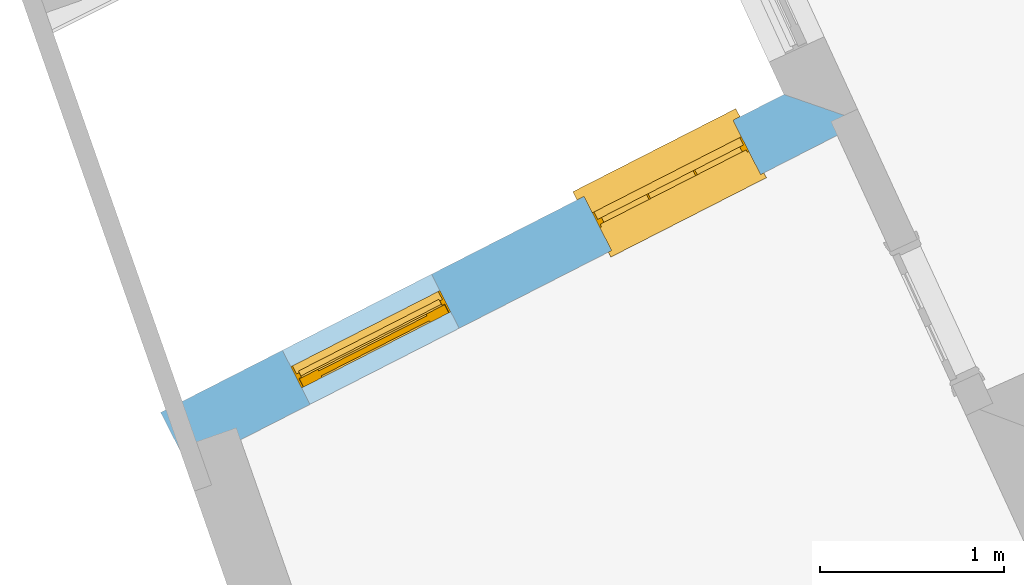
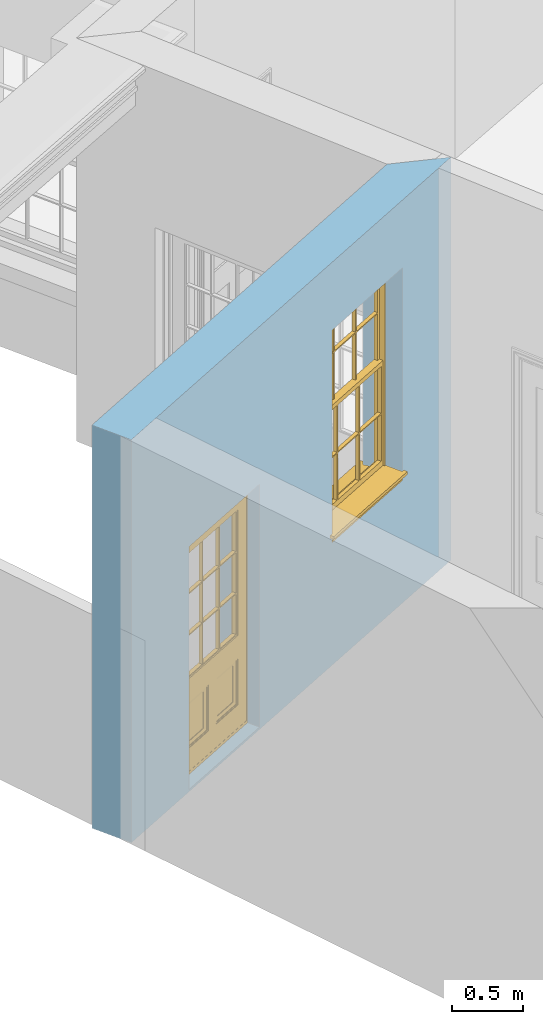
# One storey, part 2 of 10: 1 door, 1 window, 2 openings, plus 1 element that does not belong to this part.
"""IFC2X3 building model written with IfcOpenShell, lengths in metres."""

from ifc_helpers import new_model, si_unit, frame, origin, place, context, subcontext, project, spatial, polyline, outline, extrude, faceted_brep, material, layer, layer_set, layer_usage, element, fill, save


model = new_model("IFC2X3")

# Units and contexts
model_context = context("Model", 3, world=origin())
body_context = subcontext(model_context, "Body", "Model", "MODEL_VIEW")
ifc_project = project(units=[si_unit("PLANEANGLEUNIT", "RADIAN"), si_unit("MASSUNIT", "GRAM", prefix="KILO"), si_unit("FORCEUNIT", "NEWTON", prefix="KILO"), si_unit("LENGTHUNIT", "METRE")], contexts=[model_context])

# Site, building, storey
site_placement = place(None, origin())
site = spatial("IfcSite", under=ifc_project, at=site_placement, CompositionType="ELEMENT")
building_placement = place(None, origin())
building = spatial("IfcBuilding", under=site, at=building_placement, Name="Building plot-8", CompositionType="ELEMENT")
storey_placement = place(None, origin())
storey = spatial("IfcBuildingStorey", under=building, at=storey_placement, Name="Floor 0", CompositionType="ELEMENT", Elevation=0.0)

# Wall, openings, window, door
ifc_material = material(Name="Masonry")
ifc_layer = layer(ifc_material, 0.33, ventilated=False)
ifc_layer_set = layer_set([ifc_layer], Name="My Wall")
ifc_layer_usage = layer_usage(ifc_layer_set, "AXIS2", "NEGATIVE", 0.08)
wall_placement = place(storey_placement, origin())
wall = element("IfcWallStandardCase", 1, at=wall_placement, inside=storey, material=ifc_layer_usage, Name="exterior", context=body_context, shape_type="SweptSolid", body=[
    extrude(outline(polyline([(25.0188753029837, 10.5910611684611), (24.5866593596622, 10.7410148794705), (21.1992955616312, 9.01280004901607), (21.3492685706448, 8.71884750766391), (25.0188753029837, 10.5910611684611)])), origin(), (0.0, 0.0, 1.0), 3.45),
])
opening_1_placement = place(storey_placement, frame((0.0, 0.0, 1.05)))
opening_1 = element("IfcOpeningElement", 2, at=opening_1_placement, cuts=wall, Name="Opening", ObjectType="Opening", context=body_context, shape_type="SweptSolid", body=[
    extrude(outline(polyline([(24.3105588621873, 10.6001498874347), (23.4999624602768, 10.186587953488), (23.6499354692904, 9.89263541213587), (24.4605318712009, 10.3061973460826), (24.3105588621873, 10.6001498874347)])), origin(), (0.0, 0.0, 1.0), 1.82),
])
opening_2_placement = place(storey_placement, frame((0.0, 0.0, 0.02)))
opening_2 = element("IfcOpeningElement", 3, at=opening_2_placement, cuts=wall, Name="Opening", ObjectType="Opening", context=body_context, shape_type="SweptSolid", body=[
    extrude(outline(polyline([(22.6719083026935, 9.76411916628935), (21.861311900783, 9.35055723234263), (22.0112849097966, 9.05660469099047), (22.8218813117071, 9.47016662493719), (22.6719083026935, 9.76411916628935)])), origin(), (0.0, 0.0, 1.0), 2.08),
])
window_placement = place(storey_placement, frame((24.4241747781067, 10.3774585682286, 1.05), z_axis=(0.0, 0.0, 1.0), x_axis=(-0.810596401910505, -0.413561933946712, 0.0)))
window = element("IfcWindow", 4, at=window_placement, inside=storey, Name="kitchen outside window", OverallHeight=1.82, OverallWidth=0.91, context=body_context, shape_type="Brep", held_by="IfcProductRepresentation", body=[
    faceted_brep([(0.033125, -0.105, 0.975209), (0.01, -0.105, 0.975209), (0.033125, -0.105, 1.376042), (0.876875, -0.105, 0.975209), (0.876875, -0.105, 1.376042), (0.9, -0.105, 0.975209), (0.876875, -0.105, 1.386042), (0.876875, -0.105, 1.786875), (0.9, -0.105, 1.81), (0.033125, -0.105, 1.786875), (0.033125, -0.105, 1.386042), (0.01, -0.105, 1.81), (0.876875, -0.135, 1.376042), (0.876875, -0.135, 0.975209), (0.9, -0.135, 0.937083), (0.033125, -0.135, 1.786875), (0.01, -0.135, 1.81), (0.033125, -0.135, 1.386042), (0.01, -0.135, 0.937083), (0.033125, -0.135, 0.975209), (0.033125, -0.135, 1.376042), (0.876875, -0.135, 1.786875), (0.876875, -0.135, 1.386042), (0.9, -0.135, 1.81), (0.033125, -0.105, 0.937083), (0.01, -0.105, 0.937083), (0.033125, -0.105, 0.53625), (0.876875, -0.105, 0.937083), (0.876875, -0.105, 0.53625), (0.9, -0.105, 0.937083), (0.876875, -0.105, 0.52625), (0.876875, -0.105, 0.125417), (0.9, -0.105, 0.077167), (0.033125, -0.105, 0.125417), (0.033125, -0.105, 0.52625), (0.01, -0.105, 0.077167), (-0.0425, -0.25, 0.01), (-0.0425, -0.3, 0.001667), (0.0, -0.25, 0.01), (0.9525, -0.25, 0.01), (0.91, -0.25, 0.01), (0.9525, -0.3, 0.001667), (-0.02, 0.08, 0.077167), (0.0, 0.08, 0.077167), (-0.02, 0.11, 0.077167), (0.0, -0.06, 0.077167), (0.01, -0.06, 0.077167), (0.91, -0.06, 0.077167), (0.91, 0.08, 0.077167), (0.9, -0.06, 0.077167), (0.93, 0.08, 0.077167), (0.93, 0.11, 0.077167), (0.01, -0.075, 0.975209), (0.9, -0.075, 0.975209), (0.876875, -0.075, 0.125417), (0.876875, -0.075, 0.52625), (0.9, -0.075, 0.077167), (0.876875, -0.075, 0.53625), (0.876875, -0.075, 0.937083), (0.033125, -0.075, 0.125417), (0.01, -0.075, 0.077167), (0.033125, -0.075, 0.52625), (0.033125, -0.075, 0.937083), (0.033125, -0.075, 0.53625), (-0.02, 0.08, 0.052167), (-0.02, 0.11, 0.052167), (0.93, 0.11, 0.052167), (0.93, 0.08, 0.052167), (0.91, 0.08, 0.052167), (0.0, 0.08, 0.052167), (0.91, -0.15, 0.026667), (0.0, -0.15, 0.026667), (-0.0425, -0.3, -0.123333), (0.9525, -0.3, -0.123333), (-0.0425, -0.25, -0.123333), (0.9525, -0.25, -0.123333), (0.01, -0.06, 1.81), (0.9, -0.06, 1.81), (0.0, -0.06, 1.82), (0.91, -0.06, 1.82), (0.01, -0.15, 0.077167), (0.9, -0.15, 0.077167), (0.592292, -0.105, 0.125417), (0.592292, -0.075, 0.125417), (0.317708, -0.075, 0.125417), (0.317708, -0.105, 0.125417), (0.592292, -0.105, 0.53625), (0.317708, -0.105, 0.53625), (0.317708, -0.105, 0.52625), (0.592292, -0.105, 0.52625), (0.592292, -0.075, 0.53625), (0.317708, -0.075, 0.53625), (0.592292, -0.135, 1.386042), (0.592292, -0.105, 1.386042), (0.317708, -0.105, 1.386042), (0.317708, -0.135, 1.386042), (0.317708, -0.135, 1.376042), (0.592292, -0.135, 1.376042), (0.317708, -0.105, 1.376042), (0.592292, -0.105, 1.376042), (0.602292, -0.135, 1.376042), (0.592292, -0.135, 0.975209), (0.602292, -0.135, 0.975209), (0.602292, -0.105, 0.975209), (0.592292, -0.105, 0.975209), (0.602292, -0.105, 1.376042), (0.602292, -0.075, 0.53625), (0.602292, -0.105, 0.53625), (0.317708, -0.075, 0.52625), (0.307708, -0.075, 0.125417), (0.307708, -0.075, 0.52625), (0.602292, -0.075, 0.52625), (0.602292, -0.075, 0.125417), (0.592292, -0.075, 0.52625), (0.307708, -0.075, 0.53625), (0.317708, -0.075, 0.937083), (0.307708, -0.075, 0.937083), (0.602292, -0.075, 0.937083), (0.592292, -0.075, 0.937083), (0.307708, -0.105, 0.52625), (0.307708, -0.105, 0.125417), (0.307708, -0.105, 0.53625), (0.307708, -0.105, 0.937083), (0.592292, -0.105, 0.937083), (0.317708, -0.105, 0.937083), (0.602292, -0.105, 0.937083), (0.602292, -0.105, 0.52625), (0.602292, -0.105, 0.125417), (0.307708, -0.135, 1.386042), (0.307708, -0.135, 1.376042), (0.307708, -0.135, 0.975209), (0.317708, -0.135, 0.975209), (0.317708, -0.135, 1.786875), (0.307708, -0.135, 1.786875), (0.602292, -0.135, 1.786875), (0.592292, -0.135, 1.786875), (0.602292, -0.135, 1.386042), (0.602292, -0.105, 1.386042), (0.307708, -0.105, 1.386042), (0.307708, -0.105, 1.786875), (0.317708, -0.105, 1.786875), (0.592292, -0.105, 1.786875), (0.602292, -0.105, 1.786875), (0.307708, -0.105, 1.376042), (0.317708, -0.105, 0.975209), (0.307708, -0.105, 0.975209), (0.91, -0.15, 1.82), (0.9, -0.15, 1.81), (0.01, -0.15, 1.81), (0.0, -0.15, 1.82), (0.91, -0.25, 0.0), (0.0, -0.25, 0.0), (0.91, 0.08, 0.0), (0.0, 0.08, 0.0)], [[[0, 1, 2]], [[3, 4, 5]], [[6, 7, 8]], [[9, 10, 11]], [[12, 13, 14]], [[15, 16, 17]], [[18, 19, 20]], [[21, 22, 23]], [[24, 25, 26]], [[27, 28, 29]], [[30, 31, 32]], [[33, 34, 35]], [[14, 27, 29]], [[25, 24, 18]], [[36, 37, 38]], [[39, 40, 41]], [[42, 43, 44]], [[45, 46, 43]], [[47, 48, 49]], [[50, 51, 48]], [[1, 0, 52]], [[5, 53, 3]], [[54, 55, 56]], [[57, 58, 53]], [[59, 60, 61]], [[62, 63, 52]], [[48, 43, 46, 49]], [[51, 44, 43, 48]], [[64, 42, 44, 65]], [[65, 44, 51, 66]], [[66, 51, 50, 67]], [[65, 66, 68, 69]], [[60, 56, 49, 46]], [[70, 71, 38, 40]], [[37, 41, 40, 38]], [[37, 72, 73, 41]], [[74, 75, 73, 72]], [[8, 11, 76, 77]], [[76, 78, 79, 77]], [[32, 35, 80, 81]], [[81, 80, 71, 70]], [[82, 83, 84, 85]], [[86, 87, 88, 89]], [[86, 90, 91, 87]], [[92, 93, 94, 95]], [[92, 95, 96, 97]], [[96, 98, 99, 97]], [[100, 97, 101, 102]], [[103, 104, 99, 105]], [[97, 99, 104, 101]], [[102, 103, 105, 100]], [[28, 57, 106, 107]], [[108, 84, 109, 110]], [[111, 112, 83, 113]], [[114, 110, 61, 63]], [[90, 113, 108, 91]], [[115, 91, 114, 116]], [[117, 106, 90, 118]], [[111, 106, 57, 55]], [[119, 110, 109, 120]], [[34, 61, 110, 119]], [[89, 113, 83, 82]], [[88, 108, 113, 89]], [[85, 84, 108, 88]], [[121, 114, 63, 26]], [[122, 116, 114, 121]], [[123, 118, 90, 86]], [[87, 91, 115, 124]], [[107, 106, 117, 125]], [[126, 111, 55, 30]], [[127, 112, 111, 126]], [[126, 30, 28, 107]], [[88, 119, 120, 85]], [[126, 89, 82, 127]], [[125, 123, 86, 107]], [[121, 26, 34, 119]], [[124, 122, 121, 87]], [[128, 17, 20, 129]], [[96, 129, 130, 131]], [[132, 133, 128, 95]], [[134, 135, 92, 136]], [[100, 12, 22, 136]], [[137, 6, 4, 105]], [[94, 138, 139, 140]], [[137, 93, 141, 142]], [[99, 98, 94, 93]], [[143, 2, 10, 138]], [[144, 145, 143, 98]], [[129, 143, 145, 130]], [[20, 2, 143, 129]], [[131, 144, 98, 96]], [[128, 138, 10, 17]], [[133, 139, 138, 128]], [[135, 141, 93, 92]], [[95, 94, 140, 132]], [[22, 6, 137, 136]], [[136, 137, 142, 134]], [[100, 105, 4, 12]], [[107, 86, 89, 126]], [[106, 111, 113, 90]], [[91, 108, 110, 114]], [[87, 121, 119, 88]], [[97, 100, 136, 92]], [[129, 96, 95, 128]], [[98, 143, 138, 94]], [[105, 99, 93, 137]], [[131, 101, 104, 144]], [[124, 115, 118, 123]], [[132, 140, 141, 135]], [[120, 109, 59, 33]], [[15, 9, 139, 133]], [[134, 142, 7, 21]], [[31, 54, 112, 127]], [[36, 74, 72, 37]], [[39, 41, 73, 75]], [[18, 14, 101, 131]], [[23, 16, 132, 135]], [[83, 56, 60, 84]], [[52, 53, 118, 115]], [[53, 52, 144, 104]], [[11, 8, 141, 140]], [[14, 18, 124, 123]], [[2, 1, 11, 10]], [[8, 5, 4, 6]], [[57, 53, 56, 55]], [[60, 52, 63, 61]], [[26, 25, 35, 34]], [[32, 29, 28, 30]], [[14, 23, 22, 12]], [[18, 20, 17, 16]], [[19, 0, 2, 20]], [[17, 10, 9, 15]], [[12, 4, 3, 13]], [[21, 7, 6, 22]], [[27, 58, 57, 28]], [[30, 55, 54, 31]], [[33, 59, 61, 34]], [[26, 63, 62, 24]], [[5, 8, 77, 53]], [[76, 11, 1, 52]], [[46, 45, 78, 76]], [[49, 77, 79, 47]], [[70, 146, 147, 81]], [[71, 80, 148, 149]], [[19, 130, 145, 0]], [[102, 13, 3, 103]], [[116, 122, 24, 62]], [[29, 32, 81, 14]], [[80, 35, 25, 18]], [[60, 46, 76, 52]], [[77, 49, 56, 53]], [[23, 14, 81, 147]], [[16, 148, 80, 18]], [[35, 85, 120]], [[120, 33, 35]], [[127, 82, 32]], [[32, 31, 127]], [[32, 82, 85, 35]], [[102, 101, 14]], [[14, 13, 102]], [[18, 131, 130]], [[130, 19, 18]], [[134, 21, 23]], [[23, 135, 134]], [[16, 15, 133]], [[133, 132, 16]], [[11, 140, 139]], [[139, 9, 11]], [[142, 141, 8]], [[8, 7, 142]], [[23, 147, 148, 16]], [[146, 149, 148, 147]], [[52, 115, 116]], [[116, 62, 52]], [[118, 53, 117]], [[58, 117, 53]], [[27, 125, 117, 58]], [[56, 83, 112]], [[112, 54, 56]], [[109, 84, 60]], [[60, 59, 109]], [[125, 27, 14]], [[14, 123, 125]], [[122, 124, 18]], [[18, 24, 122]], [[145, 144, 52]], [[52, 0, 145]], [[103, 3, 53]], [[53, 104, 103]], [[79, 78, 149, 146]], [[78, 45, 71, 149]], [[146, 70, 47, 79]], [[150, 75, 74, 151]], [[68, 66, 67]], [[48, 68, 67, 50]], [[69, 64, 65]], [[42, 64, 69, 43]], [[69, 68, 152, 153]], [[70, 68, 48, 47]], [[150, 152, 68, 70]], [[43, 69, 71, 45]], [[69, 153, 151, 71]], [[152, 150, 151, 153]], [[38, 151, 74, 36]], [[71, 151, 38]], [[39, 75, 150, 40]], [[40, 150, 70]]]),
])
fill(opening_1, window)
door_placement = place(storey_placement, frame((22.7855242186129, 9.54142784708316, 0.02), z_axis=(0.0, 0.0, 1.0), x_axis=(-0.810596401910505, -0.413561933946712, 0.0)))
door = element("IfcDoor", 5, at=door_placement, inside=storey, Name="kitchen outside door", OverallHeight=2.08, OverallWidth=0.91, context=body_context, shape_type="Brep", held_by="IfcProductRepresentation", body=[
    faceted_brep([(0.545, -0.055, 0.265), (0.745, -0.055, 0.265), (0.745, -0.05, 0.265), (0.545, -0.05, 0.265), (0.745, -0.05, 0.58), (0.545, -0.05, 0.58), (0.545, -0.055, 0.58), (0.515, -0.06, 0.235), (0.775, -0.06, 0.235), (0.745, -0.055, 0.58), (0.515, -0.06, 0.61), (0.515, -0.065, 0.235), (0.775, -0.065, 0.235), (0.775, -0.06, 0.61), (0.515, -0.065, 0.61), (0.785, -0.065, 0.225), (0.505, -0.065, 0.225), (0.775, -0.065, 0.61), (0.505, -0.065, 0.62), (0.785, -0.065, 0.62), (0.505, -0.07, 0.225), (0.785, -0.07, 0.225), (0.505, -0.07, 0.62), (0.785, -0.07, 0.62), (0.883, -0.07, 0.075), (0.898, -0.07, 0.075), (0.405, -0.07, 0.62), (0.405, -0.07, 0.225), (0.027, -0.07, 0.075), (0.785, -0.07, 0.82), (0.125, -0.07, 0.82), (0.405, -0.065, 0.62), (0.405, -0.065, 0.225), (0.898, -0.07, 2.068), (0.027, -0.08, 0.075), (0.883, -0.08, 0.075), (0.125, -0.07, 0.225), (0.012, -0.07, 0.075), (0.785, -0.06, 0.82), (0.125, -0.06, 0.82), (0.125, -0.07, 0.62), (0.125, -0.065, 0.62), (0.395, -0.065, 0.61), (0.395, -0.065, 0.235), (0.125, -0.065, 0.225), (0.785, -0.07, 1.895), (0.027, -0.11, 0.045), (0.883, -0.11, 0.045), (0.558333, -0.06, 0.83), (0.351667, -0.06, 0.83), (0.125, -0.07, 1.895), (0.125, -0.06, 1.895), (0.785, -0.06, 1.895), (0.012, -0.07, 2.068), (0.135, -0.065, 0.61), (0.395, -0.06, 0.61), (0.395, -0.06, 0.235), (0.135, -0.065, 0.235), (0.027, -0.11, 0.027), (0.883, -0.11, 0.027), (0.568333, -0.06, 0.83), (0.558333, -0.03, 0.83), (0.351667, -0.03, 0.83), (0.341667, -0.06, 0.83), (0.135, -0.06, 1.185), (0.135, -0.06, 1.53), (0.775, -0.06, 1.53), (0.775, -0.06, 1.185), (0.135, -0.06, 0.61), (0.365, -0.055, 0.58), (0.365, -0.055, 0.265), (0.135, -0.06, 0.235), (0.568333, -0.06, 1.175), (0.558333, -0.06, 1.175), (0.775, -0.06, 0.83), (0.558333, -0.03, 1.175), (0.785, -0.03, 0.82), (0.125, -0.03, 0.82), (0.351667, -0.03, 1.175), (0.351667, -0.06, 1.175), (0.341667, -0.06, 1.175), (0.135, -0.06, 0.83), (0.135, -0.06, 1.175), (0.135, -0.03, 1.185), (0.135, -0.03, 1.53), (0.135, -0.06, 1.54), (0.351667, -0.06, 1.885), (0.558333, -0.06, 1.885), (0.775, -0.03, 1.53), (0.775, -0.03, 1.185), (0.775, -0.06, 1.175), (0.775, -0.06, 1.54), (0.165, -0.055, 0.58), (0.365, -0.05, 0.58), (0.365, -0.05, 0.265), (0.165, -0.055, 0.265), (0.568333, -0.03, 0.83), (0.568333, -0.03, 1.175), (0.568333, -0.06, 1.185), (0.558333, -0.06, 1.185), (0.775, -0.03, 0.83), (0.785, -0.02, 0.82), (0.125, -0.02, 0.82), (0.341667, -0.03, 0.83), (0.341667, -0.03, 1.175), (0.351667, -0.06, 1.185), (0.341667, -0.06, 1.185), (0.135, -0.03, 0.83), (0.341667, -0.03, 1.185), (0.125, -0.03, 1.895), (0.341667, -0.03, 1.53), (0.341667, -0.06, 1.53), (0.135, -0.06, 1.885), (0.341667, -0.06, 1.54), (0.341667, -0.06, 1.885), (0.558333, -0.03, 1.885), (0.351667, -0.03, 1.885), (0.568333, -0.06, 1.885), (0.785, -0.03, 1.895), (0.568333, -0.03, 1.185), (0.568333, -0.06, 1.53), (0.568333, -0.03, 1.53), (0.568333, -0.06, 1.54), (0.775, -0.06, 1.885), (0.165, -0.05, 0.58), (0.165, -0.05, 0.265), (0.775, -0.03, 1.175), (0.558333, -0.06, 1.53), (0.351667, -0.03, 1.185), (0.558333, -0.03, 1.185), (0.505, -0.02, 0.62), (0.405, -0.02, 0.62), (0.125, -0.02, 1.895), (0.785, -0.02, 1.895), (0.351667, -0.06, 1.53), (0.135, -0.03, 1.175), (0.135, -0.03, 1.54), (0.341667, -0.03, 1.54), (0.135, -0.03, 1.885), (0.351667, -0.06, 1.54), (0.558333, -0.03, 1.54), (0.558333, -0.06, 1.54), (0.351667, -0.03, 1.54), (0.775, -0.03, 1.54), (0.568333, -0.03, 1.54), (0.775, -0.03, 1.885), (0.558333, -0.03, 1.53), (0.405, -0.02, 0.225), (0.505, -0.02, 0.225), (0.125, -0.02, 0.62), (0.785, -0.02, 0.62), (0.012, -0.02, 2.068), (0.898, -0.02, 2.068), (0.351667, -0.03, 1.53), (0.341667, -0.03, 1.885), (0.568333, -0.03, 1.885), (0.405, -0.025, 0.225), (0.405, -0.025, 0.62), (0.505, -0.025, 0.62), (0.505, -0.025, 0.225), (0.898, -0.02, 0.027), (0.012, -0.02, 0.027), (0.125, -0.025, 0.62), (0.785, -0.025, 0.62), (0.395, -0.025, 0.235), (0.395, -0.025, 0.61), (0.125, -0.02, 0.225), (0.125, -0.025, 0.225), (0.515, -0.025, 0.61), (0.515, -0.025, 0.235), (0.785, -0.02, 0.225), (0.785, -0.025, 0.225), (0.135, -0.025, 0.61), (0.775, -0.025, 0.61), (0.135, -0.025, 0.235), (0.395, -0.03, 0.235), (0.395, -0.03, 0.61), (0.515, -0.03, 0.61), (0.515, -0.03, 0.235), (0.775, -0.025, 0.235), (0.135, -0.03, 0.61), (0.775, -0.03, 0.61), (0.135, -0.03, 0.235), (0.365, -0.035, 0.265), (0.365, -0.035, 0.58), (0.545, -0.035, 0.58), (0.545, -0.035, 0.265), (0.775, -0.03, 0.235), (0.165, -0.035, 0.58), (0.745, -0.035, 0.58), (0.165, -0.035, 0.265), (0.365, -0.04, 0.58), (0.365, -0.04, 0.265), (0.545, -0.04, 0.58), (0.545, -0.04, 0.265), (0.745, -0.035, 0.265), (0.165, -0.04, 0.58), (0.745, -0.04, 0.58), (0.165, -0.04, 0.265), (0.745, -0.04, 0.265), (0.885, -0.072, 0.025), (0.025, -0.072, 0.025), (0.025, -0.1, 0.025), (0.885, -0.1, 0.025), (0.9, -0.02, 0.025), (0.01, -0.02, 0.025), (0.9, -0.072, 0.025), (0.91, -0.02, 0.0), (0.0, -0.02, 0.0), (0.01, -0.072, 0.025), (0.9, -0.072, 2.07), (0.9, -0.02, 2.07), (0.885, -0.072, 2.055), (0.91, -0.02, 2.08), (0.01, -0.02, 2.07), (0.0, -0.02, 2.08), (0.01, -0.072, 2.07), (0.025, -0.072, 2.055), (0.0, -0.15, 2.08), (0.91, -0.15, 2.08), (0.01, -0.15, 2.07), (0.9, -0.15, 2.07), (0.01, -0.1, 2.07), (0.9, -0.1, 2.07), (0.0, -0.15, 0.0), (0.91, -0.15, 0.0), (0.01, -0.15, 0.025), (0.9, -0.15, 0.025), (0.01, -0.1, 0.025), (0.025, -0.1, 2.055), (0.9, -0.1, 0.025), (0.885, -0.1, 2.055), (0.898, -0.07, 0.027), (0.012, -0.07, 0.027), (0.883, -0.07, 0.027), (0.027, -0.07, 0.027)], [[[0, 1, 2, 3]], [[2, 4, 5, 3]], [[0, 3, 5, 6]], [[1, 0, 7, 8]], [[9, 4, 2, 1]], [[9, 6, 5, 4]], [[0, 6, 10, 7]], [[8, 7, 11, 12]], [[8, 13, 9, 1]], [[13, 10, 6, 9]], [[7, 10, 14, 11]], [[15, 12, 11, 16]], [[12, 17, 13, 8]], [[17, 14, 10, 13]], [[18, 16, 11, 14]], [[15, 19, 17, 12]], [[15, 16, 20, 21]], [[14, 17, 19, 18]], [[16, 18, 22, 20]], [[21, 23, 19, 15]], [[24, 25, 21, 20]], [[23, 22, 18, 19]], [[20, 22, 26, 27]], [[23, 21, 25]], [[28, 24, 20, 27]], [[22, 23, 29]], [[29, 30, 26, 22]], [[27, 26, 31, 32]], [[23, 25, 33, 29]], [[34, 35, 24, 28]], [[28, 27, 36, 37]], [[38, 39, 30, 29]], [[26, 30, 40]], [[26, 40, 41, 31]], [[42, 43, 32, 31]], [[32, 44, 36, 27]], [[33, 45, 29]], [[46, 47, 35, 34]], [[36, 40, 37]], [[39, 38, 48, 49]], [[50, 30, 39, 51]], [[29, 45, 52, 38]], [[53, 37, 40, 30]], [[44, 41, 40, 36]], [[31, 41, 54, 42]], [[43, 42, 55, 56]], [[57, 44, 32, 43]], [[50, 45, 33, 53]], [[47, 46, 58, 59]], [[60, 48, 38]], [[49, 48, 61, 62]], [[49, 63, 39]], [[50, 53, 30]], [[51, 39, 64, 65]], [[45, 50, 51, 52]], [[66, 67, 38, 52]], [[57, 54, 41, 44]], [[42, 54, 68, 55]], [[56, 55, 69, 70]], [[56, 71, 57, 43]], [[60, 72, 73, 48]], [[60, 38, 74]], [[48, 73, 75, 61]], [[76, 77, 62, 61]], [[62, 78, 79, 49]], [[49, 79, 80, 63]], [[63, 81, 39]], [[82, 64, 39]], [[65, 64, 83, 84]], [[85, 51, 65]], [[52, 51, 86, 87]], [[88, 89, 67, 66]], [[90, 38, 67]], [[91, 66, 52]], [[71, 68, 54, 57]], [[55, 68, 92, 69]], [[69, 93, 94, 70]], [[70, 95, 71, 56]], [[96, 97, 72, 60]], [[73, 72, 98, 99]], [[74, 38, 90]], [[100, 96, 60, 74]], [[75, 73, 79, 78]], [[61, 75, 97, 96]], [[101, 102, 77, 76]], [[77, 103, 62]], [[96, 76, 61]], [[103, 104, 78, 62]], [[80, 79, 105, 106]], [[63, 80, 104, 103]], [[81, 63, 103, 107]], [[81, 82, 39]], [[106, 64, 82, 80]], [[106, 108, 83, 64]], [[84, 83, 77, 109]], [[110, 111, 65, 84]], [[112, 51, 85]], [[113, 85, 65, 111]], [[114, 86, 51]], [[115, 87, 86, 116]], [[117, 52, 87]], [[118, 76, 89, 88]], [[119, 98, 67, 89]], [[120, 121, 88, 66]], [[67, 98, 72, 90]], [[91, 122, 120, 66]], [[91, 52, 123]], [[95, 92, 68, 71]], [[69, 92, 124, 93]], [[94, 93, 124, 125]], [[94, 125, 95, 70]], [[72, 97, 126, 90]], [[127, 99, 98, 120]], [[99, 105, 79, 73]], [[74, 90, 126, 100]], [[96, 100, 76]], [[128, 129, 75, 78]], [[97, 75, 129, 119]], [[130, 131, 102, 101]], [[109, 77, 102, 132]], [[133, 101, 76, 118]], [[77, 107, 103]], [[78, 104, 108, 128]], [[111, 106, 105, 134]], [[104, 80, 82, 135]], [[107, 135, 82, 81]], [[110, 108, 106, 111]], [[104, 135, 83, 108]], [[83, 135, 77]], [[136, 84, 109]], [[110, 84, 136, 137]], [[114, 51, 112]], [[85, 136, 138, 112]], [[113, 137, 136, 85]], [[111, 134, 139, 113]], [[86, 114, 113, 139]], [[140, 141, 87, 115]], [[139, 142, 116, 86]], [[109, 118, 115, 116]], [[117, 123, 52]], [[117, 87, 141, 122]], [[126, 89, 76]], [[143, 118, 88]], [[120, 98, 119, 121]], [[119, 89, 126, 97]], [[144, 143, 88, 121]], [[144, 122, 91, 143]], [[127, 120, 122, 141]], [[143, 91, 123, 145]], [[124, 92, 95, 125]], [[146, 129, 99, 127]], [[99, 129, 128, 105]], [[100, 126, 76]], [[121, 119, 129, 146]], [[147, 131, 130, 148]], [[131, 149, 102]], [[130, 101, 150]], [[102, 151, 132]], [[118, 109, 132, 133]], [[101, 133, 152]], [[107, 77, 135]], [[153, 128, 108, 110]], [[134, 105, 128, 153]], [[109, 138, 136]], [[153, 110, 137, 142]], [[154, 114, 112, 138]], [[137, 113, 114, 154]], [[141, 139, 134, 127]], [[141, 140, 142, 139]], [[144, 140, 115, 155]], [[142, 137, 154, 116]], [[155, 115, 118]], [[116, 154, 109]], [[117, 155, 145, 123]], [[122, 144, 155, 117]], [[143, 145, 118]], [[121, 146, 140, 144]], [[146, 127, 134, 153]], [[156, 157, 131, 147]], [[148, 130, 158, 159]], [[148, 160, 161, 147]], [[157, 162, 149, 131]], [[161, 151, 102, 149]], [[101, 152, 160, 150]], [[163, 158, 130, 150]], [[151, 152, 133, 132]], [[154, 138, 109]], [[142, 140, 146, 153]], [[145, 155, 118]], [[157, 156, 164, 165]], [[147, 166, 167, 156]], [[168, 169, 159, 158]], [[170, 148, 159, 171]], [[148, 170, 160]], [[166, 147, 161]], [[172, 162, 157, 165]], [[166, 149, 162, 167]], [[166, 161, 149]], [[150, 160, 170]], [[163, 173, 168, 158]], [[171, 163, 150, 170]], [[174, 164, 156, 167]], [[175, 176, 165, 164]], [[169, 168, 177, 178]], [[171, 159, 169, 179]], [[167, 162, 172, 174]], [[176, 180, 172, 165]], [[179, 173, 163, 171]], [[181, 177, 168, 173]], [[164, 174, 182, 175]], [[183, 184, 176, 175]], [[178, 177, 185, 186]], [[179, 169, 178, 187]], [[174, 172, 180, 182]], [[184, 188, 180, 176]], [[187, 181, 173, 179]], [[189, 185, 177, 181]], [[175, 182, 190, 183]], [[191, 184, 183, 192]], [[185, 193, 194, 186]], [[187, 178, 186, 195]], [[182, 180, 188, 190]], [[191, 196, 188, 184]], [[195, 189, 181, 187]], [[197, 193, 185, 189]], [[183, 190, 198, 192]], [[198, 196, 191, 192]], [[194, 193, 197, 199]], [[195, 186, 194, 199]], [[188, 196, 198, 190]], [[197, 189, 195, 199]], [[200, 201, 202, 203]], [[201, 200, 204, 205]], [[206, 204, 200]], [[204, 207, 208, 205]], [[209, 201, 205]], [[210, 211, 204, 206]], [[206, 200, 212, 210]], [[211, 213, 207, 204]], [[214, 205, 208, 215]], [[216, 217, 201, 209]], [[205, 214, 216, 209]], [[216, 214, 211, 210]], [[210, 212, 217, 216]], [[214, 215, 213, 211]], [[218, 219, 213, 215]], [[219, 218, 220, 221]], [[221, 220, 222, 223]], [[215, 208, 224, 218]], [[225, 224, 208, 207]], [[224, 226, 220, 218]], [[224, 225, 227, 226]], [[219, 225, 207, 213]], [[228, 222, 220, 226]], [[219, 221, 227, 225]], [[226, 227, 203, 202]], [[202, 229, 222, 228]], [[228, 226, 202]], [[227, 221, 223, 230]], [[230, 203, 227]], [[217, 229, 202, 201]], [[231, 223, 222, 229]], [[230, 223, 231, 203]], [[231, 229, 217, 212]], [[212, 200, 203, 231]], [[33, 152, 151, 53]], [[25, 160, 152, 33]], [[161, 37, 53, 151]], [[232, 160, 25]], [[161, 233, 37]], [[160, 232, 234]], [[24, 234, 232, 25]], [[233, 161, 235]], [[37, 233, 235, 28]], [[161, 160, 234, 235]], [[35, 47, 234, 24]], [[28, 235, 46, 34]], [[58, 235, 234, 59]], [[59, 234, 47]], [[58, 46, 235]]]),
])
fill(opening_2, door)

save(model, "model.ifc")
